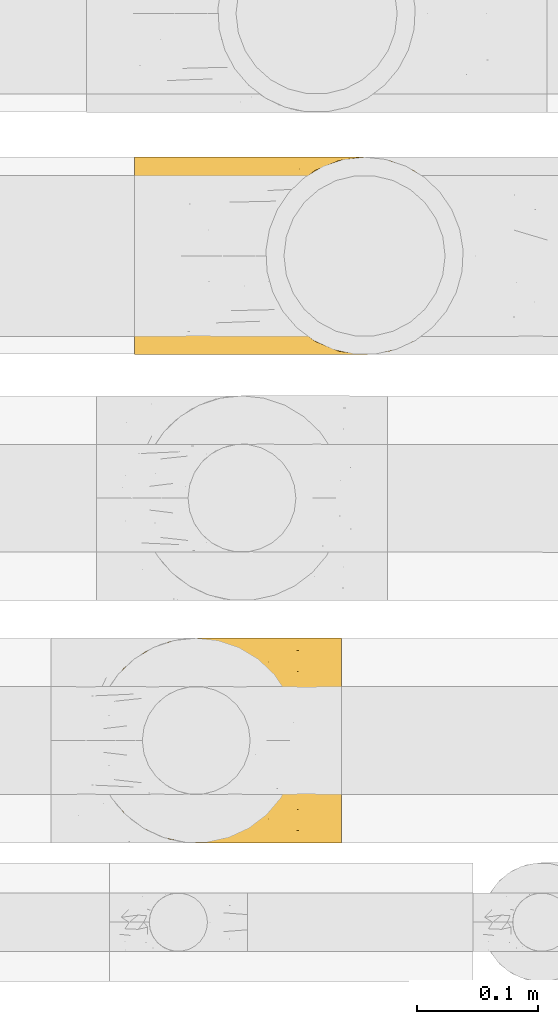
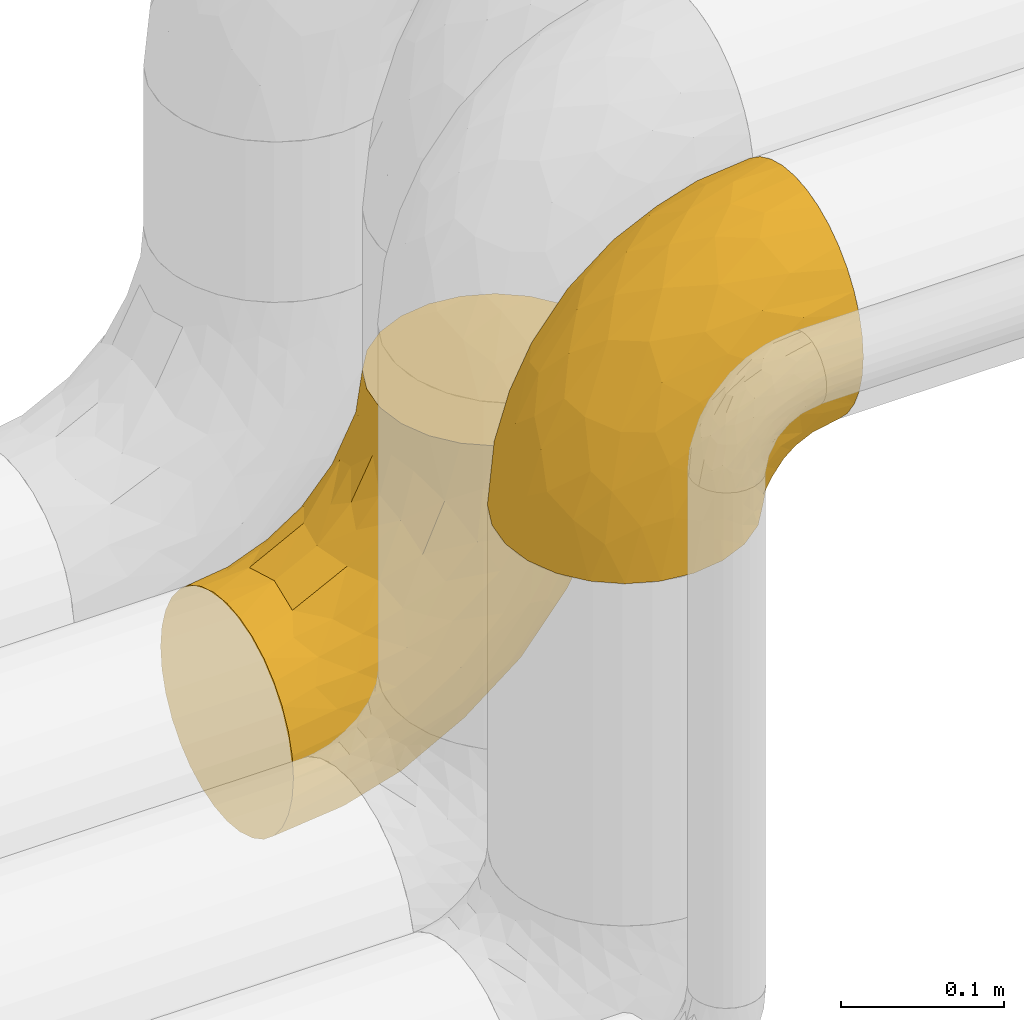
# One storey, part 17 of 93: 2 coverings.
"""IFC2X3 building model written with IfcOpenShell, lengths in millimetres."""

from ifc_helpers import new_model, entity, si_unit, converted_unit, derived_unit, direction, frame, origin, place, context, subcontext, project, spatial, faceted_brep, element, save


model = new_model("IFC2X3")

# Units and contexts
model_context = context("Model", 3, precision=0.01, world=origin(), true_north=direction((6.12303176911189e-17, 1.0)))
body_context = subcontext(model_context, "Body", "Model", "MODEL_VIEW")
ifc_project = project(units=[si_unit("LENGTHUNIT", "METRE", prefix="MILLI"), si_unit("AREAUNIT", "SQUARE_METRE"), si_unit("VOLUMEUNIT", "CUBIC_METRE"), converted_unit("PLANEANGLEUNIT", "DEGREE", entity("IfcRatioMeasure", 0.0174532925199433), si_unit("PLANEANGLEUNIT", "RADIAN"), dimensions=[0, 0, 0, 0, 0, 0, 0]), si_unit("MASSUNIT", "GRAM", prefix="KILO"), derived_unit("MASSDENSITYUNIT", [(si_unit("MASSUNIT", "GRAM", prefix="KILO"), 1), (si_unit("LENGTHUNIT", "METRE"), -3)]), derived_unit("MOMENTOFINERTIAUNIT", [(si_unit("LENGTHUNIT", "METRE"), 4)]), si_unit("TIMEUNIT", "SECOND"), si_unit("FREQUENCYUNIT", "HERTZ"), si_unit("THERMODYNAMICTEMPERATUREUNIT", "DEGREE_CELSIUS"), derived_unit("THERMALTRANSMITTANCEUNIT", [(si_unit("MASSUNIT", "GRAM", prefix="KILO"), 1), (si_unit("THERMODYNAMICTEMPERATUREUNIT", "KELVIN"), -1), (si_unit("TIMEUNIT", "SECOND"), -3)]), derived_unit("VOLUMETRICFLOWRATEUNIT", [(si_unit("LENGTHUNIT", "METRE"), 3), (si_unit("TIMEUNIT", "SECOND"), -1)]), derived_unit("MASSFLOWRATEUNIT", [(si_unit("MASSUNIT", "GRAM", prefix="KILO"), 1), (si_unit("TIMEUNIT", "SECOND"), -1)]), derived_unit("ROTATIONALFREQUENCYUNIT", [(si_unit("TIMEUNIT", "SECOND"), -1)]), si_unit("ELECTRICCURRENTUNIT", "AMPERE"), si_unit("ELECTRICVOLTAGEUNIT", "VOLT"), si_unit("POWERUNIT", "WATT"), si_unit("FORCEUNIT", "NEWTON", prefix="KILO"), si_unit("ILLUMINANCEUNIT", "LUX"), si_unit("LUMINOUSFLUXUNIT", "LUMEN"), si_unit("LUMINOUSINTENSITYUNIT", "CANDELA"), derived_unit("USERDEFINED", [(si_unit("MASSUNIT", "GRAM", prefix="KILO"), -1), (si_unit("LENGTHUNIT", "METRE"), -2), (si_unit("TIMEUNIT", "SECOND"), 3), (si_unit("LUMINOUSFLUXUNIT", "LUMEN"), 1)]), derived_unit("LINEARVELOCITYUNIT", [(si_unit("LENGTHUNIT", "METRE"), 1), (si_unit("TIMEUNIT", "SECOND"), -1)]), si_unit("PRESSUREUNIT", "PASCAL"), derived_unit("USERDEFINED", [(si_unit("LENGTHUNIT", "METRE"), -2), (si_unit("MASSUNIT", "GRAM", prefix="KILO"), 1), (si_unit("TIMEUNIT", "SECOND"), -2)]), derived_unit("LINEARFORCEUNIT", [(si_unit("MASSUNIT", "GRAM", prefix="KILO"), 1), (si_unit("LENGTHUNIT", "METRE"), 1), (si_unit("TIMEUNIT", "SECOND"), -2), (si_unit("LENGTHUNIT", "METRE"), -1)]), derived_unit("PLANARFORCEUNIT", [(si_unit("MASSUNIT", "GRAM", prefix="KILO"), 1), (si_unit("LENGTHUNIT", "METRE"), 1), (si_unit("TIMEUNIT", "SECOND"), -2), (si_unit("LENGTHUNIT", "METRE"), -2)])], contexts=[model_context])

# Site, building, storey
site_placement = place(None, origin())
site = spatial("IfcSite", under=ifc_project, at=site_placement, CompositionType="ELEMENT")
building_placement = place(site_placement, origin())
building = spatial("IfcBuilding", under=site, at=building_placement, CompositionType="ELEMENT")
storey_placement = place(building_placement, frame((0.0, 0.0, -4200.0)))
storey = spatial("IfcBuildingStorey", under=building, at=storey_placement, CompositionType="ELEMENT", Elevation=-4200.0)

# Coverings
covering_1_placement = place(storey_placement, frame((-2077.19, 13813.91, 2878.41)))
element("IfcCovering", 1, at=covering_1_placement, inside=storey, Name=":ADSK_", ObjectType=":ADSK_", PredefinedType="INSULATION", context=body_context, shape_type="Brep", body=[
    faceted_brep([(206.1, 165.5, 150.5), (206.1, 159.27, 163.85), (206.1, 150.82, 175.91), (206.1, 140.41, 186.33), (206.1, 128.34, 194.77), (206.1, 115.0, 201.0), (206.1, 100.77, 204.81), (206.1, 86.1, 206.1), (206.1, 71.42, 204.81), (206.1, 57.19, 201.0), (206.1, 43.84, 194.77), (206.1, 31.78, 186.32), (206.1, 21.36, 175.91), (206.1, 12.92, 163.84), (206.1, 6.69, 150.5), (206.1, 2.88, 136.27), (206.1, 1.6, 121.6), (206.1, 2.88, 106.92), (206.1, 6.69, 92.69), (206.1, 12.92, 79.34), (206.1, 21.37, 67.28), (206.1, 31.78, 56.86), (206.1, 43.85, 48.42), (206.1, 57.19, 42.19), (206.1, 71.42, 38.38), (206.1, 86.1, 37.1), (206.1, 100.77, 38.38), (206.1, 115.0, 42.19), (206.1, 128.35, 48.42), (206.1, 140.41, 56.87), (206.1, 150.83, 67.28), (206.1, 159.27, 79.35), (206.1, 165.5, 92.69), (206.1, 167.41, 99.81), (206.1, 169.31, 106.92), (206.1, 170.6, 121.6), (206.1, 169.31, 136.27), (170.6, 86.1, 1.6), (167.72, 64.23, 1.6), (159.27, 43.85, 1.6), (145.85, 26.34, 1.6), (128.35, 12.92, 1.6), (107.97, 4.47, 1.6), (99.56, 3.37, 1.6), (86.1, 1.6, 1.6), (64.23, 4.47, 1.6), (43.85, 12.92, 1.6), (26.34, 26.34, 1.6), (12.92, 43.85, 1.6), (4.47, 64.23, 1.6), (1.6, 86.1, 1.6), (4.47, 107.97, 1.6), (12.92, 128.35, 1.6), (26.34, 145.85, 1.6), (43.85, 159.27, 1.6), (64.23, 167.72, 1.6), (86.1, 170.6, 1.6), (99.56, 168.82, 1.6), (107.97, 167.72, 1.6), (118.16, 163.5, 1.6), (128.35, 159.27, 1.6), (145.85, 145.85, 1.6), (159.27, 128.35, 1.6), (167.72, 107.97, 1.6), (6.72, 86.1, 47.1), (21.85, 86.1, 90.32), (17.49, 101.8, 76.74), (7.72, 101.53, 45.07), (13.94, 115.31, 54.43), (78.7, 144.07, 130.85), (68.47, 153.55, 102.9), (51.33, 140.98, 101.57), (46.21, 86.1, 129.1), (33.86, 101.78, 109.1), (53.79, 161.76, 42.18), (110.17, 142.72, 157.11), (145.81, 150.74, 165.26), (118.82, 155.51, 145.37), (169.84, 143.09, 180.34), (63.0, 104.94, 144.69), (78.59, 86.1, 161.48), (99.74, 108.34, 172.76), (34.35, 151.11, 29.38), (21.32, 134.54, 42.46), (162.31, 119.08, 194.48), (140.29, 102.34, 193.55), (173.87, 105.3, 201.3), (73.41, 168.18, 46.37), (106.28, 167.9, 101.41), (135.56, 170.6, 98.68), (122.29, 170.6, 85.4), (109.01, 170.6, 72.13), (136.01, 164.11, 137.0), (96.64, 159.97, 119.7), (139.72, 169.12, 119.97), (169.01, 170.6, 115.72), (152.29, 170.6, 107.2), (86.47, 167.97, 76.04), (100.49, 170.6, 55.4), (91.97, 170.6, 38.68), (117.37, 86.1, 185.84), (127.74, 128.7, 177.95), (169.45, 160.38, 157.62), (40.66, 148.22, 65.3), (73.41, 162.92, 82.09), (80.23, 125.81, 149.99), (160.59, 86.1, 200.97), (167.92, 168.04, 136.93), (191.28, 170.6, 119.25), (180.15, 170.6, 117.49), (37.92, 120.0, 104.96), (32.9, 135.81, 75.57), (90.21, 170.6, 27.54), (88.44, 170.6, 16.41), (149.02, 157.07, 48.91), (161.35, 154.23, 55.45), (160.46, 145.03, 39.69), (124.9, 164.3, 35.54), (112.91, 169.15, 48.76), (124.31, 167.13, 52.0), (111.82, 167.63, 27.71), (104.11, 168.98, 19.57), (136.85, 156.82, 26.99), (129.63, 159.34, 16.3), (183.96, 144.95, 56.69), (174.77, 138.16, 44.9), (144.17, 148.65, 14.18), (188.35, 86.1, 32.34), (178.24, 104.92, 26.88), (190.53, 101.3, 35.03), (163.14, 123.52, 12.19), (191.92, 128.61, 46.38), (170.99, 104.0, 14.56), (174.51, 121.86, 31.42), (165.01, 129.84, 25.84), (190.2, 160.87, 80.65), (189.17, 153.1, 67.99), (171.39, 165.79, 86.7), (190.71, 169.24, 105.36), (185.21, 116.6, 37.11), (156.15, 166.95, 82.94), (168.99, 159.05, 69.47), (147.47, 165.68, 71.96), (185.14, 167.57, 96.9), (196.12, 112.04, 39.9), (155.54, 136.39, 14.17), (135.37, 165.43, 58.72), (137.28, 160.11, 40.86), (122.5, 169.43, 66.83), (175.35, 86.1, 19.35), (147.86, 147.96, 24.13), (178.24, 67.27, 26.89), (124.75, 3.35, 64.55), (140.4, 8.36, 58.43), (134.79, 3.59, 74.15), (190.53, 70.9, 35.03), (157.46, 29.26, 32.21), (167.05, 31.85, 40.64), (153.29, 18.75, 45.95), (170.99, 68.18, 14.56), (192.44, 43.83, 46.39), (185.67, 27.99, 56.57), (131.94, 8.25, 47.33), (148.18, 27.75, 12.22), (147.71, 23.54, 25.77), (137.3, 17.03, 20.39), (178.55, 34.05, 47.38), (106.23, 3.69, 18.5), (125.2, 10.28, 18.72), (110.01, 3.79, 32.32), (124.9, 7.89, 35.54), (116.08, 3.11, 53.79), (187.44, 3.05, 104.3), (185.21, 55.6, 37.11), (109.01, 1.6, 72.13), (196.13, 60.15, 39.9), (163.78, 18.43, 56.59), (191.28, 1.6, 119.25), (180.15, 1.6, 117.49), (90.21, 1.6, 27.54), (88.44, 1.6, 16.41), (189.79, 19.33, 67.82), (181.87, 8.94, 83.63), (163.9, 44.79, 20.61), (162.06, 3.77, 92.44), (173.37, 3.17, 100.06), (168.81, 11.99, 71.69), (142.59, 3.08, 84.22), (122.29, 1.6, 85.4), (169.01, 1.6, 115.72), (173.17, 48.4, 31.34), (150.79, 7.81, 70.29), (152.29, 1.6, 107.2), (135.56, 1.6, 98.68), (91.97, 1.6, 38.68), (100.49, 1.6, 55.4), (106.28, 4.29, 101.41), (90.96, 2.95, 72.18), (118.83, 16.68, 145.37), (169.45, 11.81, 157.62), (145.81, 21.44, 165.25), (33.86, 70.41, 109.1), (17.49, 70.39, 76.74), (37.92, 52.19, 104.96), (73.4, 4.01, 46.36), (73.41, 9.27, 82.09), (96.64, 12.22, 119.7), (53.79, 10.43, 42.18), (110.16, 29.47, 157.11), (78.7, 28.12, 130.84), (7.72, 70.66, 45.07), (167.93, 4.15, 136.93), (99.74, 63.85, 172.76), (63.0, 67.25, 144.69), (80.23, 46.37, 149.99), (13.94, 56.88, 54.43), (127.74, 43.49, 177.94), (34.35, 21.08, 29.38), (40.66, 23.97, 65.31), (32.91, 36.39, 75.58), (21.32, 37.65, 42.46), (169.84, 29.09, 180.33), (139.72, 3.07, 119.97), (136.02, 8.08, 137.0), (68.47, 18.64, 102.89), (51.33, 31.2, 101.56), (162.31, 53.1, 194.48), (140.29, 69.85, 193.55), (173.87, 66.89, 201.3)], [[[0, 1, 2, 3, 4, 5, 6, 7, 8, 9, 10, 11, 12, 13, 14, 15, 16, 17, 18, 19, 20, 21, 22, 23, 24, 25, 26, 27, 28, 29, 30, 31, 32, 33, 34, 35, 36]], [[37, 38, 39, 40, 41, 42, 43, 44, 45, 46, 47, 48, 49, 50, 51, 52, 53, 54, 55, 56, 57, 58, 59, 60, 61, 62, 63]], [[64, 65, 66]], [[67, 50, 64]], [[68, 52, 51]], [[69, 70, 71]], [[72, 73, 65]], [[54, 74, 55]], [[75, 76, 77]], [[65, 73, 66]], [[2, 78, 3]], [[79, 80, 81]], [[53, 82, 54]], [[53, 52, 83]], [[52, 68, 83]], [[84, 85, 86]], [[74, 87, 55]], [[88, 89, 90, 91]], [[92, 93, 77]], [[56, 55, 87]], [[94, 95, 96, 89]], [[92, 88, 93]], [[97, 91, 98, 99]], [[93, 70, 69]], [[81, 80, 100]], [[101, 81, 85]], [[76, 1, 102]], [[74, 103, 104]], [[5, 4, 84]], [[84, 4, 78]], [[80, 79, 72]], [[84, 86, 5]], [[77, 102, 92]], [[3, 78, 4]], [[101, 75, 105]], [[106, 7, 6]], [[100, 106, 85]], [[76, 78, 2]], [[107, 35, 108, 109, 95]], [[107, 95, 94]], [[94, 88, 92]], [[79, 105, 110]], [[71, 103, 111]], [[0, 107, 102]], [[84, 78, 101]], [[97, 99, 87]], [[66, 67, 64]], [[1, 76, 2]], [[0, 102, 1]], [[76, 101, 78]], [[107, 0, 36]], [[81, 100, 85]], [[88, 94, 89]], [[93, 88, 104]], [[107, 94, 92]], [[105, 79, 81]], [[73, 79, 110]], [[101, 105, 81]], [[105, 69, 71]], [[111, 68, 110]], [[82, 83, 103]], [[102, 107, 92]], [[107, 36, 35]], [[74, 54, 82]], [[87, 74, 104]], [[97, 87, 104]], [[87, 99, 112, 113, 56]], [[70, 93, 104]], [[77, 76, 102]], [[86, 106, 6]], [[85, 84, 101]], [[79, 73, 72]], [[66, 110, 68]], [[110, 66, 73]], [[66, 68, 67]], [[68, 51, 67]], [[50, 67, 51]], [[104, 103, 70]], [[71, 70, 103]], [[111, 103, 83]], [[105, 71, 110]], [[68, 111, 83]], [[110, 71, 111]], [[93, 69, 77]], [[75, 77, 69]], [[105, 75, 69]], [[101, 76, 75]], [[106, 86, 85]], [[5, 86, 6]], [[83, 82, 53]], [[74, 82, 103]], [[104, 88, 97]], [[91, 97, 88]], [[114, 115, 116]], [[113, 112, 58, 57, 56]], [[117, 118, 119]], [[120, 121, 99]], [[120, 99, 98]], [[117, 122, 123]], [[124, 125, 115]], [[62, 61, 126]], [[127, 128, 129]], [[115, 125, 116]], [[130, 63, 62]], [[28, 131, 124]], [[132, 37, 63]], [[133, 132, 134]], [[135, 136, 137]], [[138, 108, 34]], [[128, 139, 129]], [[89, 96, 140]], [[140, 141, 142]], [[32, 31, 143]], [[34, 33, 32, 138]], [[29, 124, 136]], [[141, 124, 115]], [[135, 31, 30]], [[116, 125, 133]], [[35, 34, 108]], [[28, 27, 131]], [[124, 141, 136]], [[144, 131, 27]], [[127, 129, 25]], [[139, 144, 129]], [[95, 109, 108, 138]], [[134, 130, 145]], [[28, 124, 29]], [[29, 136, 30]], [[121, 120, 59]], [[27, 26, 144]], [[124, 131, 125]], [[146, 114, 147]], [[115, 114, 142]], [[131, 139, 125]], [[117, 147, 122]], [[125, 139, 133]], [[135, 143, 31]], [[143, 137, 96]], [[142, 90, 89]], [[137, 136, 141]], [[146, 119, 148]], [[115, 142, 141]], [[119, 146, 147]], [[142, 146, 148]], [[141, 140, 137]], [[26, 25, 129]], [[131, 144, 139]], [[136, 135, 30]], [[143, 135, 137]], [[26, 129, 144]], [[128, 127, 149]], [[132, 128, 149]], [[133, 139, 128]], [[37, 132, 149]], [[132, 63, 130]], [[134, 150, 116]], [[119, 147, 117]], [[150, 114, 116]], [[142, 114, 146]], [[114, 150, 147]], [[122, 147, 150]], [[98, 118, 120]], [[148, 119, 91]], [[118, 117, 120]], [[119, 118, 91]], [[91, 118, 98]], [[123, 120, 117]], [[58, 112, 121]], [[91, 90, 148]], [[142, 148, 90]], [[132, 133, 128]], [[133, 134, 116]], [[142, 89, 140]], [[95, 143, 96]], [[150, 126, 122]], [[123, 61, 60]], [[123, 122, 126]], [[120, 123, 60]], [[126, 150, 145]], [[123, 126, 61]], [[140, 96, 137]], [[145, 130, 62]], [[132, 130, 134]], [[126, 145, 62]], [[134, 145, 150]], [[32, 143, 138]], [[95, 138, 143]], [[121, 112, 99]], [[120, 60, 59]], [[58, 121, 59]], [[149, 127, 151]], [[152, 153, 154]], [[127, 155, 151]], [[156, 157, 158]], [[159, 149, 151]], [[159, 37, 149]], [[160, 22, 161]], [[153, 152, 162]], [[163, 164, 165]], [[166, 160, 161]], [[167, 41, 168]], [[169, 170, 171]], [[169, 168, 170]], [[168, 165, 170]], [[172, 19, 18]], [[166, 173, 160]], [[174, 171, 152]], [[24, 175, 155]], [[176, 158, 157]], [[17, 16, 177, 178]], [[42, 167, 179]], [[160, 23, 22]], [[175, 24, 23]], [[180, 44, 43, 42, 179]], [[20, 181, 21]], [[182, 20, 19]], [[21, 181, 161]], [[21, 161, 22]], [[39, 38, 183]], [[184, 182, 185]], [[186, 161, 181]], [[172, 18, 17]], [[187, 188, 154]], [[161, 176, 166]], [[185, 19, 172]], [[178, 189, 172]], [[178, 172, 17]], [[151, 173, 190]], [[164, 163, 183]], [[155, 25, 24]], [[166, 176, 157]], [[175, 160, 173]], [[153, 176, 191]], [[20, 182, 181]], [[186, 181, 182]], [[185, 182, 19]], [[172, 189, 185]], [[189, 192, 185]], [[187, 184, 193]], [[184, 185, 192]], [[160, 175, 23]], [[155, 175, 173]], [[155, 173, 151]], [[155, 127, 25]], [[173, 166, 190]], [[159, 183, 38]], [[193, 184, 192]], [[186, 182, 184]], [[159, 151, 190]], [[37, 159, 38]], [[176, 161, 186]], [[166, 157, 190]], [[191, 176, 186]], [[158, 176, 153]], [[187, 186, 184]], [[191, 154, 153]], [[156, 190, 157]], [[188, 152, 154]], [[159, 190, 183]], [[162, 158, 153]], [[156, 158, 164]], [[164, 183, 156]], [[190, 156, 183]], [[187, 154, 191]], [[152, 188, 174]], [[171, 170, 162]], [[152, 171, 162]], [[167, 169, 194]], [[169, 195, 194]], [[169, 167, 168]], [[174, 195, 171]], [[169, 171, 195]], [[165, 162, 170]], [[158, 162, 164]], [[187, 191, 186]], [[188, 187, 193]], [[41, 167, 42]], [[41, 40, 168]], [[165, 164, 162]], [[168, 40, 165]], [[163, 165, 40]], [[40, 39, 163]], [[183, 163, 39]], [[167, 194, 179]], [[196, 197, 174]], [[198, 199, 200]], [[201, 202, 203]], [[204, 44, 180, 179, 194]], [[205, 196, 206]], [[204, 205, 207]], [[204, 197, 205]], [[196, 174, 188, 193]], [[198, 208, 209]], [[65, 201, 72]], [[50, 49, 210]], [[211, 189, 178, 177, 16]], [[212, 213, 214]], [[49, 48, 215]], [[214, 216, 212]], [[217, 207, 218]], [[217, 47, 46]], [[210, 215, 202]], [[199, 13, 200]], [[219, 215, 220]], [[213, 80, 72]], [[221, 12, 11]], [[222, 193, 192, 189]], [[199, 223, 211]], [[16, 15, 211]], [[212, 100, 80]], [[216, 200, 221]], [[199, 211, 14]], [[14, 13, 199]], [[206, 196, 223]], [[12, 221, 200]], [[218, 224, 225]], [[222, 196, 193]], [[13, 12, 200]], [[221, 11, 10]], [[10, 226, 221]], [[80, 213, 212]], [[226, 227, 216]], [[212, 216, 227]], [[226, 10, 9]], [[228, 106, 227]], [[100, 227, 106]], [[7, 106, 8]], [[48, 220, 215]], [[228, 9, 8]], [[216, 221, 226]], [[223, 198, 206]], [[45, 207, 46]], [[206, 224, 205]], [[223, 222, 211]], [[48, 47, 220]], [[64, 210, 202]], [[196, 222, 223]], [[201, 213, 72]], [[203, 225, 214]], [[203, 214, 213]], [[214, 209, 208]], [[217, 220, 47]], [[218, 225, 219]], [[189, 211, 222]], [[211, 15, 14]], [[45, 44, 204]], [[218, 207, 205]], [[45, 204, 207]], [[197, 194, 195, 174]], [[223, 199, 198]], [[224, 206, 209]], [[212, 227, 100]], [[228, 227, 226]], [[202, 201, 65]], [[213, 201, 203]], [[64, 202, 65]], [[203, 202, 215]], [[50, 210, 64]], [[49, 215, 210]], [[225, 224, 209]], [[218, 205, 224]], [[214, 225, 209]], [[218, 219, 220]], [[225, 203, 219]], [[215, 219, 203]], [[208, 198, 200]], [[209, 206, 198]], [[200, 216, 208]], [[214, 208, 216]], [[9, 228, 226]], [[106, 228, 8]], [[207, 217, 46]], [[220, 217, 218]], [[205, 197, 196]], [[194, 197, 204]]]),
])
covering_2_placement = place(storey_placement, frame((-2043.78, 14216.91, 2416.9)))
element("IfcCovering", 2, at=covering_2_placement, inside=storey, Name=":ADSK_", ObjectType=":ADSK_", PredefinedType="INSULATION", context=body_context, shape_type="Brep", body=[
    faceted_brep([(1.6, 158.39, 51.91), (1.6, 150.86, 37.82), (1.6, 140.72, 25.47), (1.6, 128.37, 15.33), (1.6, 114.28, 7.8), (1.6, 98.99, 3.16), (1.6, 83.1, 1.6), (1.6, 67.2, 3.16), (1.6, 51.91, 7.8), (1.6, 37.82, 15.33), (1.6, 25.47, 25.47), (1.6, 15.33, 37.82), (1.6, 7.8, 51.91), (1.6, 3.16, 67.2), (1.6, 1.6, 83.1), (1.6, 3.16, 99.0), (1.6, 7.8, 114.28), (1.6, 15.33, 128.37), (1.6, 25.47, 140.72), (1.6, 37.82, 150.86), (1.6, 51.91, 158.39), (1.6, 67.2, 163.03), (1.6, 83.1, 164.6), (1.6, 99.0, 163.03), (1.6, 114.28, 158.39), (1.6, 128.37, 150.86), (1.6, 140.72, 140.72), (1.6, 150.86, 128.37), (1.6, 158.39, 114.28), (1.6, 163.03, 98.99), (1.6, 164.6, 83.1), (1.6, 163.03, 67.2), (112.87, 62.0, 273.1), (121.01, 42.35, 273.1), (133.97, 25.47, 273.1), (150.85, 12.51, 273.1), (170.5, 4.37, 273.1), (191.6, 1.6, 273.1), (212.69, 4.37, 273.1), (232.35, 12.51, 273.1), (249.22, 25.47, 273.1), (262.18, 42.35, 273.1), (270.32, 62.0, 273.1), (273.1, 83.1, 273.1), (270.32, 104.19, 273.1), (262.18, 123.85, 273.1), (249.22, 140.72, 273.1), (232.35, 153.68, 273.1), (212.69, 161.82, 273.1), (191.6, 164.6, 273.1), (170.5, 161.82, 273.1), (150.85, 153.68, 273.1), (133.97, 140.72, 273.1), (121.01, 123.85, 273.1), (112.87, 104.19, 273.1), (110.1, 83.1, 273.1), (259.24, 104.67, 197.18), (267.88, 83.1, 220.13), (252.43, 83.1, 169.2), (232.27, 132.71, 165.22), (203.25, 128.57, 112.74), (208.72, 140.31, 136.63), (161.26, 127.0, 69.59), (208.94, 111.93, 106.1), (171.1, 107.33, 65.75), (210.75, 96.47, 101.73), (56.09, 153.13, 47.92), (234.92, 119.3, 151.7), (237.78, 101.32, 143.42), (135.85, 142.92, 67.74), (90.98, 142.61, 44.25), (106.5, 151.87, 64.23), (203.21, 162.56, 221.53), (172.78, 164.6, 190.66), (186.83, 164.6, 230.82), (227.34, 83.1, 122.26), (107.06, 117.97, 31.44), (61.85, 119.64, 17.25), (100.97, 131.15, 37.36), (193.57, 83.1, 81.12), (152.43, 83.1, 47.35), (218.24, 156.52, 210.98), (227.74, 144.21, 181.7), (239.64, 146.25, 232.28), (250.37, 130.43, 211.28), (43.87, 164.6, 87.86), (78.77, 162.51, 79.61), (181.88, 159.97, 152.2), (192.35, 151.26, 136.41), (151.91, 151.21, 92.77), (261.16, 117.68, 226.05), (125.68, 158.25, 89.58), (120.31, 163.04, 104.94), (62.42, 105.24, 11.64), (114.22, 100.78, 28.2), (43.77, 144.52, 33.2), (175.87, 141.87, 98.82), (55.94, 132.77, 24.35), (105.49, 83.1, 22.26), (54.56, 83.1, 6.81), (84.03, 164.6, 101.91), (120.06, 164.6, 124.55), (150.14, 164.6, 154.63), (143.53, 151.23, 242.08), (124.28, 137.69, 231.65), (164.08, 161.34, 233.63), (63.41, 141.27, 155.43), (34.09, 138.72, 146.77), (50.98, 127.05, 162.22), (71.3, 109.71, 184.19), (35.12, 83.1, 169.91), (65.37, 83.1, 185.32), (103.16, 120.43, 213.9), (108.14, 138.75, 197.8), (82.77, 129.2, 180.95), (101.65, 161.91, 136.57), (76.68, 161.43, 123.35), (87.17, 155.97, 145.64), (149.53, 162.57, 185.45), (116.92, 160.03, 157.77), (116.45, 151.82, 182.66), (114.12, 117.14, 245.12), (32.67, 109.48, 164.57), (26.08, 148.92, 133.28), (54.1, 151.93, 136.47), (137.51, 154.85, 206.49), (108.77, 98.92, 248.1), (99.57, 100.98, 222.02), (89.37, 83.1, 209.32), (104.78, 83.1, 239.57), (90.24, 145.5, 167.88), (36.38, 158.16, 118.7), (57.28, 162.97, 108.44), (28.92, 162.71, 102.71), (83.96, 98.76, 200.15), (153.13, 160.15, 211.84), (24.92, 124.12, 155.81), (103.17, 154.06, 162.83), (137.51, 11.34, 206.49), (124.28, 28.5, 231.65), (108.14, 27.44, 197.8), (116.45, 14.37, 182.66), (108.77, 67.27, 248.1), (99.57, 65.22, 222.02), (50.98, 39.14, 162.22), (63.41, 24.93, 155.43), (82.77, 36.99, 180.95), (28.92, 3.48, 102.71), (71.3, 56.48, 184.19), (143.53, 14.96, 242.08), (164.08, 4.85, 233.63), (24.92, 42.07, 155.81), (34.09, 27.47, 146.78), (103.16, 45.76, 213.9), (83.96, 67.43, 200.15), (57.28, 3.22, 108.44), (36.38, 8.03, 118.7), (186.83, 1.6, 230.82), (114.12, 49.05, 245.12), (26.08, 17.27, 133.28), (32.67, 56.71, 164.57), (162.83, 3.08, 206.34), (149.53, 3.62, 185.45), (84.03, 1.6, 101.91), (120.06, 1.6, 124.55), (76.68, 4.76, 123.35), (150.14, 1.6, 154.63), (172.78, 1.6, 190.66), (90.24, 20.69, 167.88), (116.92, 6.16, 157.77), (54.1, 14.26, 136.47), (87.17, 10.22, 145.64), (101.65, 4.28, 136.57), (43.87, 1.6, 87.86), (102.74, 12.35, 162.96), (250.37, 35.76, 211.28), (90.98, 23.58, 44.25), (100.94, 35.03, 37.35), (141.5, 34.03, 59.81), (45.45, 46.35, 14.04), (195.08, 3.68, 195.92), (169.75, 3.15, 154.38), (185.11, 7.94, 149.02), (175.87, 24.32, 98.82), (190.61, 41.48, 94.45), (122.49, 6.22, 92.81), (75.94, 2.91, 82.48), (212.14, 57.48, 108.3), (215.84, 10.43, 198.33), (234.04, 33.0, 169.99), (227.74, 21.98, 181.7), (210.82, 28.1, 135.99), (252.63, 47.91, 192.96), (43.77, 21.67, 33.21), (171.1, 58.86, 65.75), (67.05, 13.93, 49.37), (234.92, 46.89, 151.7), (240.01, 62.93, 148.6), (239.64, 19.94, 232.28), (259.24, 61.52, 197.18), (124.28, 15.08, 72.78), (63.96, 6.68, 63.87), (114.23, 65.41, 28.2), (195.27, 16.65, 136.17), (159.59, 11.53, 107.34), (62.43, 60.95, 11.64), (55.94, 33.42, 24.35), (107.06, 48.22, 31.44)], [[[0, 1, 2, 3, 4, 5, 6, 7, 8, 9, 10, 11, 12, 13, 14, 15, 16, 17, 18, 19, 20, 21, 22, 23, 24, 25, 26, 27, 28, 29, 30, 31]], [[32, 33, 34, 35, 36, 37, 38, 39, 40, 41, 42, 43, 44, 45, 46, 47, 48, 49, 50, 51, 52, 53, 54, 55]], [[56, 57, 58]], [[57, 44, 43]], [[59, 60, 61]], [[62, 63, 64]], [[63, 65, 64]], [[1, 0, 66]], [[67, 68, 63]], [[69, 70, 71]], [[72, 73, 74]], [[75, 68, 58]], [[76, 77, 78]], [[64, 79, 80]], [[81, 48, 47]], [[82, 83, 84]], [[31, 85, 86]], [[71, 70, 66]], [[47, 83, 81]], [[87, 88, 89]], [[69, 62, 78]], [[49, 48, 72]], [[90, 44, 56]], [[48, 81, 72]], [[87, 91, 92]], [[93, 76, 94]], [[70, 95, 66]], [[88, 96, 89]], [[45, 84, 46]], [[2, 95, 97]], [[4, 93, 5]], [[98, 99, 93]], [[59, 84, 67]], [[3, 97, 77]], [[71, 86, 91]], [[4, 3, 77]], [[90, 84, 45]], [[99, 6, 5]], [[83, 47, 46]], [[95, 2, 1]], [[94, 80, 98]], [[100, 101, 92]], [[66, 31, 86]], [[60, 63, 62]], [[85, 31, 30]], [[102, 87, 92]], [[93, 77, 76]], [[91, 86, 92]], [[44, 57, 56]], [[86, 85, 100]], [[78, 97, 70]], [[87, 102, 73]], [[2, 97, 3]], [[67, 84, 90]], [[31, 66, 0]], [[93, 94, 98]], [[88, 81, 82]], [[99, 5, 93]], [[87, 73, 72]], [[66, 95, 1]], [[97, 95, 70]], [[86, 71, 66]], [[69, 89, 96]], [[89, 71, 91]], [[69, 96, 62]], [[60, 62, 96]], [[76, 62, 64]], [[71, 89, 69]], [[87, 89, 91]], [[81, 88, 87]], [[61, 88, 82]], [[61, 60, 96]], [[60, 67, 63]], [[68, 67, 56]], [[79, 65, 75]], [[58, 68, 56]], [[65, 68, 75]], [[64, 65, 79]], [[68, 65, 63]], [[76, 64, 94]], [[80, 94, 64]], [[100, 92, 86]], [[92, 101, 102]], [[88, 61, 96]], [[59, 61, 82]], [[84, 59, 82]], [[60, 59, 67]], [[87, 72, 81]], [[49, 72, 74]], [[84, 83, 46]], [[81, 83, 82]], [[69, 78, 70]], [[62, 76, 78]], [[4, 77, 93]], [[78, 77, 97]], [[44, 90, 45]], [[67, 90, 56]], [[103, 104, 52]], [[50, 49, 74]], [[50, 74, 105]], [[106, 107, 108]], [[109, 110, 111]], [[112, 113, 114]], [[104, 113, 112]], [[73, 105, 74]], [[115, 116, 117]], [[118, 119, 120]], [[104, 53, 52]], [[51, 103, 52]], [[53, 121, 54]], [[24, 23, 122]], [[123, 107, 124]], [[122, 109, 108]], [[125, 120, 113]], [[55, 54, 126]], [[102, 118, 73]], [[127, 126, 121]], [[128, 129, 127]], [[105, 51, 50]], [[102, 101, 119]], [[120, 130, 113]], [[26, 123, 27]], [[27, 131, 28]], [[132, 85, 133]], [[85, 29, 133]], [[134, 111, 128]], [[28, 133, 29]], [[30, 29, 85]], [[116, 131, 124]], [[135, 73, 118]], [[27, 123, 131]], [[110, 23, 22]], [[136, 122, 108]], [[24, 136, 25]], [[114, 108, 109]], [[119, 115, 117]], [[136, 107, 25]], [[128, 127, 134]], [[122, 110, 109]], [[104, 112, 121]], [[107, 106, 124]], [[107, 26, 25]], [[23, 110, 122]], [[101, 100, 116]], [[131, 132, 133]], [[105, 135, 103]], [[116, 124, 117]], [[122, 136, 24]], [[107, 136, 108]], [[28, 131, 133]], [[131, 116, 132]], [[126, 127, 129]], [[134, 112, 109]], [[107, 123, 26]], [[131, 123, 124]], [[104, 121, 53]], [[127, 121, 112]], [[105, 103, 51]], [[104, 103, 125]], [[116, 100, 132]], [[85, 132, 100]], [[106, 117, 124]], [[137, 130, 120]], [[114, 106, 108]], [[106, 130, 117]], [[119, 118, 102]], [[135, 118, 125]], [[125, 113, 104]], [[114, 113, 130]], [[114, 130, 106]], [[112, 114, 109]], [[118, 120, 125]], [[117, 137, 119]], [[55, 126, 129]], [[121, 126, 54]], [[112, 134, 127]], [[111, 134, 109]], [[119, 101, 115]], [[101, 116, 115]], [[103, 135, 125]], [[73, 135, 105]], [[130, 137, 117]], [[120, 119, 137]], [[138, 139, 140]], [[140, 141, 138]], [[55, 129, 142]], [[143, 142, 129]], [[144, 145, 146]], [[147, 16, 15]], [[110, 148, 111]], [[128, 143, 129]], [[149, 150, 35]], [[151, 152, 144]], [[153, 143, 154]], [[147, 155, 156]], [[35, 150, 36]], [[37, 36, 157]], [[35, 34, 149]], [[139, 33, 158]], [[159, 152, 18]], [[150, 157, 36]], [[140, 139, 153]], [[139, 34, 33]], [[110, 21, 160]], [[150, 161, 157]], [[20, 19, 151]], [[161, 138, 162]], [[110, 22, 21]], [[163, 164, 165]], [[166, 167, 162]], [[151, 160, 20]], [[140, 146, 168]], [[111, 148, 154]], [[164, 166, 169]], [[18, 152, 19]], [[170, 156, 165]], [[17, 159, 18]], [[158, 33, 32]], [[171, 165, 172]], [[155, 165, 156]], [[148, 110, 160]], [[170, 159, 156]], [[160, 144, 148]], [[15, 14, 173]], [[170, 171, 145]], [[149, 139, 138]], [[15, 173, 147]], [[144, 152, 145]], [[156, 17, 16]], [[165, 171, 170]], [[20, 160, 21]], [[171, 172, 169]], [[169, 166, 162]], [[152, 151, 19]], [[160, 151, 144]], [[155, 173, 163]], [[156, 16, 147]], [[154, 143, 128]], [[143, 153, 158]], [[156, 159, 17]], [[152, 159, 170]], [[158, 32, 142]], [[139, 158, 153]], [[139, 149, 34]], [[150, 149, 138]], [[173, 155, 147]], [[163, 165, 155]], [[174, 169, 141]], [[145, 171, 168]], [[170, 145, 152]], [[146, 145, 168]], [[161, 162, 167]], [[162, 138, 141]], [[146, 153, 148]], [[140, 168, 141]], [[153, 146, 140]], [[144, 146, 148]], [[174, 141, 168]], [[162, 141, 169]], [[158, 142, 143]], [[55, 142, 32]], [[111, 154, 128]], [[153, 154, 148]], [[165, 164, 172]], [[164, 169, 172]], [[157, 161, 167]], [[138, 161, 150]], [[168, 171, 174]], [[169, 174, 171]], [[41, 40, 175]], [[176, 177, 178]], [[9, 8, 179]], [[180, 181, 182]], [[157, 180, 37]], [[183, 178, 184]], [[164, 185, 181]], [[13, 186, 173]], [[187, 79, 75]], [[167, 166, 181]], [[186, 163, 173]], [[182, 188, 180]], [[57, 43, 42]], [[189, 190, 191]], [[164, 186, 185]], [[192, 41, 175]], [[193, 11, 10]], [[178, 194, 184]], [[12, 11, 195]], [[196, 187, 197]], [[40, 198, 175]], [[198, 40, 39]], [[58, 199, 197]], [[200, 185, 201]], [[163, 186, 164]], [[201, 185, 186]], [[202, 80, 194]], [[190, 203, 191]], [[201, 186, 13]], [[204, 185, 200]], [[201, 13, 12]], [[41, 199, 42]], [[195, 200, 201]], [[98, 205, 99]], [[57, 42, 199]], [[13, 173, 14]], [[58, 57, 199]], [[193, 206, 176]], [[80, 79, 194]], [[207, 205, 202]], [[196, 184, 187]], [[202, 205, 98]], [[205, 179, 8]], [[9, 206, 10]], [[207, 206, 179]], [[182, 203, 188]], [[6, 99, 7]], [[188, 38, 180]], [[203, 182, 204]], [[7, 205, 8]], [[37, 180, 38]], [[167, 180, 157]], [[7, 99, 205]], [[182, 181, 185]], [[11, 193, 195]], [[196, 191, 184]], [[175, 189, 192]], [[198, 188, 190]], [[38, 188, 39]], [[206, 193, 10]], [[195, 193, 176]], [[195, 176, 200]], [[12, 195, 201]], [[178, 200, 176]], [[185, 204, 182]], [[200, 183, 204]], [[203, 204, 183]], [[191, 203, 183]], [[188, 203, 190]], [[184, 191, 183]], [[190, 189, 175]], [[200, 178, 183]], [[184, 194, 187]], [[177, 176, 206]], [[194, 178, 207]], [[79, 187, 194]], [[197, 199, 192]], [[187, 75, 197]], [[58, 197, 75]], [[191, 196, 189]], [[192, 189, 196]], [[80, 202, 98]], [[194, 207, 202]], [[167, 181, 180]], [[181, 166, 164]], [[188, 198, 39]], [[175, 198, 190]], [[207, 179, 205]], [[9, 179, 206]], [[197, 192, 196]], [[41, 192, 199]], [[206, 207, 177]], [[207, 178, 177]]]),
])

save(model, "model.ifc")
